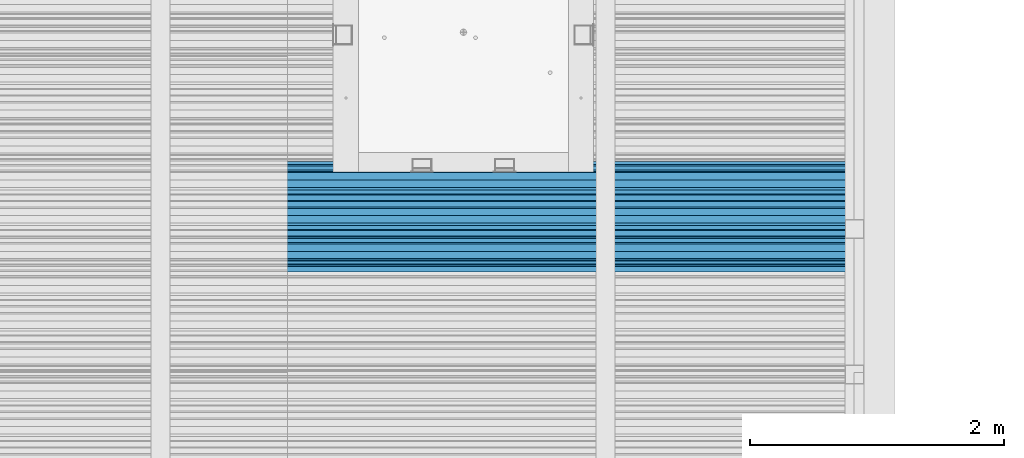
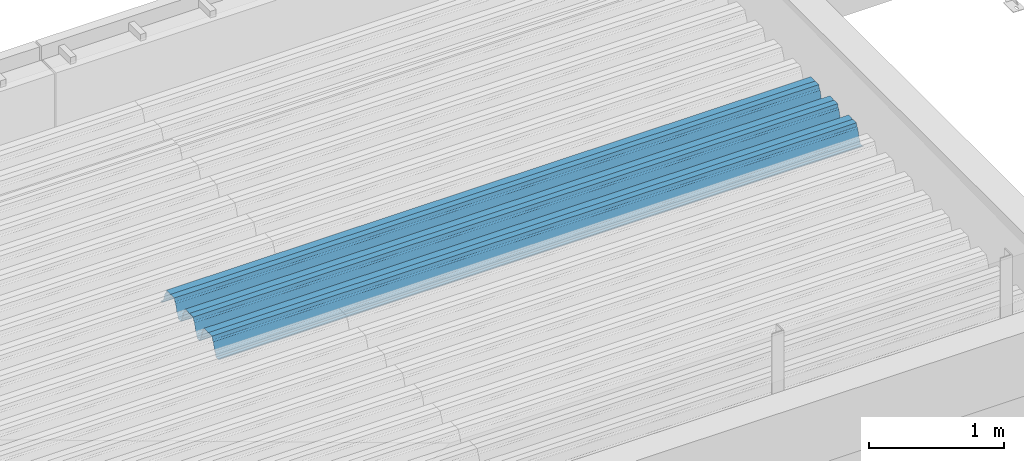
# One storey, part 38 of 153: 1 beam, 1 element without a shape of its own.
"""IFC2X3 building model written with IfcOpenShell, lengths in millimetres."""

from ifc_helpers import new_model, si_unit, frame, origin_with_axes, place, context, subcontext, project, spatial, faceted_brep, material, type_object, element, aggregate, save


model = new_model("IFC2X3")

# Units and contexts
model_context = context("Model", 3, precision=1e-05, world=origin_with_axes())
body_context = subcontext(model_context, "Body", "Model", "MODEL_VIEW")
ifc_project = project(units=[si_unit("LENGTHUNIT", "METRE", prefix="MILLI"), si_unit("AREAUNIT", "SQUARE_METRE"), si_unit("VOLUMEUNIT", "CUBIC_METRE"), si_unit("MASSUNIT", "GRAM", prefix="KILO"), si_unit("TIMEUNIT", "SECOND"), si_unit("PLANEANGLEUNIT", "RADIAN"), si_unit("SOLIDANGLEUNIT", "STERADIAN"), si_unit("THERMODYNAMICTEMPERATUREUNIT", "DEGREE_CELSIUS"), si_unit("LUMINOUSINTENSITYUNIT", "LUMEN")], contexts=[model_context])

# Site, building, storey
site_placement = place(None, origin_with_axes())
site = spatial("IfcSite", under=ifc_project, at=site_placement, CompositionType="ELEMENT")
building_placement = place(site_placement, origin_with_axes())
building = spatial("IfcBuilding", under=site, at=building_placement, CompositionType="ELEMENT")
storey_placement = place(building_placement, origin_with_axes())
storey = spatial("IfcBuildingStorey", under=building, at=storey_placement, Name="8", CompositionType="ELEMENT", Elevation=0.0)

# Assembly, beam
assembly_placement = place(storey_placement, origin_with_axes())
assembly = element("IfcElementAssembly", 1, at=assembly_placement, inside=storey, Name="Steel Assembly", AssemblyPlace="NOTDEFINED", PredefinedType="RIGID_FRAME")
ifc_material = material(Name="STEEL/S355J2")
beam_type = type_object("IfcBeamType", Name="W", PredefinedType="NOTDEFINED")
beam_placement = place(assembly_placement, frame((21782.0, 17875.0145456904, 105781.023065477), z_axis=(0.0, -0.0124990270013869, 0.999921884110963), x_axis=(-1.0, 3.00000001838171e-08, 0.0)))
beam = element("IfcBeam", 2, at=beam_placement, type_object=beam_type, material=ifc_material, ObjectType="W", context=body_context, shape_type="Brep", body=[
    faceted_brep([(0.0, -412.839996337891, -77.0100021362159), (0.0, -409.160003662109, -77.0100021362014), (5530.0, -409.160003662109, -77.0100021362014), (5530.0, -412.839996337891, -77.0100021362159), (0.0, -408.070007324222, -73.4800033569045), (5530.0, -408.070007324222, -73.4800033569045), (0.0, -400.339996337894, -48.0600013732619), (5530.0, -400.339996337894, -48.0600013732619), (0.0, -399.459991455082, -46.5600013732619), (5530.0, -399.459991455082, -46.5600013732619), (0.0, -390.329986572269, -36.5499992370314), (5530.0, -390.329986572269, -36.5499992370314), (0.0, -389.19000244141, -34.6300010680861), (5530.0, -389.19000244141, -34.6300010680861), (0.0, -367.820007324222, 35.3400001526024), (5530.0, -367.820007324222, 35.3400001526024), (0.0, -366.989990234379, 36.8499984741502), (5530.0, -366.989990234379, 36.8499984741502), (0.0, -357.809997558597, 46.8600006103807), (5530.0, -357.809997558597, 46.8600006103807), (0.0, -356.720001220707, 48.7700004577782), (5530.0, -356.720001220707, 48.7700004577782), (0.0, -349.309997558594, 73.1500015258935), (5530.0, -349.309997558594, 73.1500015258935), (0.0, -347.850006103516, 75.2300033569481), (5530.0, -347.850006103516, 75.2300033569481), (0.0, -345.470001220707, 76.010002136245), (5530.0, -345.470001220707, 76.010002136245), (0.0, -305.480010986332, 76.010002136245), (5530.0, -305.480010986332, 76.010002136245), (0.0, -304.279998779301, 75.8000030517578), (5530.0, -304.279998779301, 75.8000030517578), (0.0, -291.679992675785, 71.6999969482567), (5530.0, -291.679992675785, 71.6999969482567), (0.0, -290.179992675789, 71.2300033569481), (5530.0, -290.179992675789, 71.2300033569481), (0.0, -288.720001220707, 71.6999969482567), (5530.0, -288.720001220707, 71.6999969482567), (0.0, -276.119995117191, 75.8000030517869), (5530.0, -276.119995117191, 75.8000030517869), (0.0, -274.929992675785, 76.010002136245), (5530.0, -274.929992675785, 76.010002136245), (0.0, -234.94000244141, 76.010002136245), (5530.0, -234.94000244141, 76.010002136245), (0.0, -232.550003051758, 75.2300033569627), (5530.0, -232.550003051758, 75.2300033569627), (0.0, -231.100006103519, 73.1500015258935), (5530.0, -231.100006103519, 73.1500015258935), (0.0, -223.679992675785, 48.7700004577782), (5530.0, -223.679992675785, 48.7700004577782), (0.0, -222.589996337894, 46.8600006103661), (5530.0, -222.589996337894, 46.8600006103661), (0.0, -213.410003662113, 36.8499984741502), (5530.0, -213.410003662113, 36.8499984741502), (0.0, -212.529998779301, 35.3400001526024), (5530.0, -212.529998779301, 35.3400001526024), (0.0, -191.160003662109, -34.6300010681007), (5530.0, -191.160003662109, -34.6300010681007), (0.0, -190.070007324222, -36.5499992370605), (5530.0, -190.070007324222, -36.5499992370605), (0.0, -180.940002441406, -46.560001373291), (5530.0, -180.940002441406, -46.560001373291), (0.0, -180.059997558597, -48.0600013732619), (5530.0, -180.059997558597, -48.0600013732619), (0.0, -172.330001831055, -73.480003356919), (5530.0, -172.330001831055, -73.480003356919), (0.0, -171.240005493168, -77.0100021362159), (5530.0, -171.240005493168, -77.0100021362159), (0.0, -129.330001831062, -77.0100021362014), (5530.0, -129.330001831062, -77.0100021362014), (0.0, -128.300003051761, -73.480003356919), (5530.0, -128.300003051761, -73.480003356919), (0.0, -120.51999664307, -48.0600013732765), (5530.0, -120.51999664307, -48.0600013732765), (0.0, -119.629997253418, -46.5600013732765), (5530.0, -119.629997253418, -46.5600013732765), (0.0, -110.500000000004, -36.5499992370314), (5530.0, -110.500000000004, -36.5499992370314), (0.0, -109.419998168949, -34.6300010680861), (5530.0, -109.419998168949, -34.6300010680861), (0.0, -88.0500030517615, 35.3400001526024), (5530.0, -88.0500030517615, 35.3400001526024), (0.0, -87.160003662113, 36.8499984741356), (5530.0, -87.160003662113, 36.8499984741356), (0.0, -78.0400009155273, 46.8600006103807), (5530.0, -78.0400009155273, 46.8600006103807), (0.0, -76.8899993896557, 48.7700004577782), (5530.0, -76.8899993896557, 48.7700004577782), (0.0, -69.4800033569336, 73.1500015258935), (5530.0, -69.4800033569336, 73.1500015258935), (0.0, -68.0299987793042, 75.2300033569336), (5530.0, -68.0299987793042, 75.2300033569336), (0.0, -65.6399993896521, 76.010002136245), (5530.0, -65.6399993896521, 76.010002136245), (0.0, -25.6499996185375, 76.0100021362596), (5530.0, -25.6499996185375, 76.0100021362596), (0.0, -24.5100002288891, 75.8000030517724), (5530.0, -24.5100002288891, 75.8000030517724), (0.0, -11.8500003814697, 71.6999969482567), (5530.0, -11.8500003814697, 71.6999969482567), (0.0, -10.3999996185339, 71.2300033569481), (5530.0, -10.3999996185339, 71.2300033569481), (0.0, -8.89999961853391, 71.6999969482567), (5530.0, -8.89999961853391, 71.6999969482567), (0.0, 3.71000003814333, 75.8000030517724), (5530.0, 3.71000003814333, 75.8000030517724), (0.0, 4.90000009536379, 76.0100021362596), (5530.0, 4.90000009536379, 76.0100021362596), (0.0, 44.8899993896484, 76.010002136245), (5530.0, 44.8899993896484, 76.010002136245), (0.0, 47.2799987792932, 75.2300033569481), (5530.0, 47.2799987792932, 75.2300033569481), (0.0, 48.6800003051721, 73.1500015258935), (5530.0, 48.6800003051721, 73.1500015258935), (0.0, 56.1500015258753, 48.7700004577782), (5530.0, 56.1500015258753, 48.7700004577782), (0.0, 57.2400016784632, 46.8600006103807), (5530.0, 57.2400016784632, 46.8600006103807), (0.0, 66.3700027465784, 36.8499984741211), (5530.0, 66.3700027465784, 36.8499984741211), (0.0, 67.2499999999964, 35.3400001526024), (5530.0, 67.2499999999964, 35.3400001526024), (0.0, 88.6200027465748, -34.6300010681007), (5530.0, 88.6200027465748, -34.6300010681007), (0.0, 89.709999084469, -36.549999237046), (5530.0, 89.709999084469, -36.549999237046), (0.0, 98.8899993896412, -46.5600013732765), (5530.0, 98.8899993896412, -46.5600013732765), (0.0, 99.7699966430628, -48.0600013732765), (5530.0, 99.7699966430628, -48.0600013732765), (0.0, 107.499999999996, -73.4800033569336), (5530.0, 107.499999999996, -73.4800033569336), (0.0, 108.589996337887, -77.0100021362014), (5530.0, 108.589996337887, -77.0100021362014), (0.0, 112.269996643063, -77.0100021362159), (5530.0, 112.269996643063, -77.0100021362159), (0.0, 146.759994506836, -77.0100021362159), (5530.0, 146.759994506836, -77.0100021362159), (0.0, 150.440002441403, -77.0100021362159), (5530.0, 150.440002441403, -77.0100021362159), (0.0, 151.529998779297, -73.480003356919), (5530.0, 151.529998779297, -73.480003356919), (0.0, 159.30999755859, -48.0600013732765), (5530.0, 159.30999755859, -48.0600013732765), (0.0, 160.190002441406, -46.5600013732619), (5530.0, 160.190002441406, -46.5600013732619), (0.0, 169.320007324215, -36.549999237046), (5530.0, 169.320007324215, -36.549999237046), (0.0, 170.410003662106, -34.6300010680861), (5530.0, 170.410003662106, -34.6300010680861), (0.0, 191.779998779293, 35.3400001526024), (5530.0, 191.779998779293, 35.3400001526024), (0.0, 192.660003662109, 36.8499984741502), (5530.0, 192.660003662109, 36.8499984741502), (0.0, 201.789993286129, 46.8600006103661), (5530.0, 201.789993286129, 46.8600006103661), (0.0, 202.880004882809, 48.7700004577637), (5530.0, 202.880004882809, 48.7700004577637), (0.0, 210.350006103512, 73.150001525908), (5530.0, 210.350006103512, 73.150001525908), (0.0, 211.800003051754, 75.2300033569481), (5530.0, 211.800003051754, 75.2300033569481), (0.0, 214.190002441406, 76.010002136245), (5530.0, 214.190002441406, 76.010002136245), (0.0, 254.179992675778, 76.010002136245), (5530.0, 254.179992675778, 76.010002136245), (0.0, 255.320007324215, 75.8000030517869), (5530.0, 255.320007324215, 75.8000030517869), (0.0, 267.980010986324, 71.6999969482713), (5530.0, 267.980010986324, 71.6999969482713), (0.0, 269.429992675778, 71.2300033569481), (5530.0, 269.429992675778, 71.2300033569481), (0.0, 270.880004882809, 71.6999969482567), (5530.0, 270.880004882809, 71.6999969482567), (0.0, 283.540008544918, 75.8000030517869), (5530.0, 283.540008544918, 75.8000030517869), (0.0, 284.679992675778, 76.010002136245), (5530.0, 284.679992675778, 76.010002136245), (0.0, 324.670013427731, 76.010002136245), (5530.0, 324.670013427731, 76.010002136245), (0.0, 327.049987792969, 75.2300033569627), (5530.0, 327.049987792969, 75.2300033569627), (0.0, 328.510009765625, 73.1500015258789), (5530.0, 328.510009765625, 73.1500015258789), (0.0, 335.980010986324, 48.7700004577782), (5530.0, 335.980010986324, 48.7700004577782), (0.0, 337.05999755859, 46.8600006103661), (5530.0, 337.05999755859, 46.8600006103661), (0.0, 346.190002441399, 36.8499984741356), (5530.0, 346.190002441399, 36.8499984741356), (0.0, 347.079986572266, 35.3400001526024), (5530.0, 347.079986572266, 35.3400001526024), (0.0, 368.450012207028, -34.6300010680861), (5530.0, 368.450012207028, -34.6300010680861), (0.0, 369.529998779293, -36.5499992370314), (5530.0, 369.529998779293, -36.5499992370314), (0.0, 378.660003662106, -46.5600013732619), (5530.0, 378.660003662106, -46.5600013732619), (0.0, 379.540008544918, -48.0600013732619), (5530.0, 379.540008544918, -48.0600013732619), (0.0, 387.329986572262, -73.480003356919), (5530.0, 387.329986572262, -73.480003356919), (0.0, 388.410003662109, -77.0100021362159), (5530.0, 388.410003662109, -77.0100021362159), (0.0, 392.100006103512, -77.0100021362159), (5530.0, 392.100006103512, -77.0100021362159), (0.0, 426.589996337887, -77.0100021362159), (5530.0, 426.589996337887, -77.0100021362159), (0.0, 430.269989013668, -77.0100021362159), (5530.0, 430.269989013668, -77.0100021362159), (0.0, 431.359985351559, -73.4800033569045), (5530.0, 431.359985351559, -73.4800033569045), (0.0, 433.179992675778, -67.5699996948097), (5530.0, 433.179992675778, -67.5699996948097), (0.0, 432.220001220699, -67.2699966430373), (5530.0, 432.220001220699, -67.2699966430373), (0.0, 430.410003662106, -73.1800003051612), (5530.0, 430.410003662106, -73.1800003051612), (0.0, 429.529998779293, -76.0100021362159), (5530.0, 429.529998779293, -76.0100021362159), (0.0, 426.589996337891, -76.0100021362159), (5530.0, 426.589996337891, -76.0100021362159), (0.0, 392.100006103512, -76.0100021362159), (5530.0, 392.100006103512, -76.0100021362159), (0.0, 389.149993896481, -76.0100021362014), (5530.0, 389.149993896481, -76.0100021362014), (0.0, 388.279998779293, -73.1800003051467), (5530.0, 388.279998779293, -73.1800003051467), (0.0, 380.470001220699, -47.659999847383), (5530.0, 380.470001220699, -47.659999847383), (0.0, 379.470001220699, -45.9599990844436), (5530.0, 379.470001220699, -45.9599990844436), (0.0, 370.350006103512, -35.9599990844581), (5530.0, 370.350006103512, -35.9599990844581), (0.0, 369.369995117184, -34.2299995422218), (5530.0, 369.369995117184, -34.2299995422218), (0.0, 347.999999999996, 35.7500000000146), (5530.0, 347.999999999996, 35.7500000000146), (0.0, 346.999999999996, 37.4399986267235), (5530.0, 346.999999999996, 37.4399986267235), (0.0, 337.880004882809, 47.450000762954), (5530.0, 337.880004882809, 47.450000762954), (0.0, 336.899993896481, 49.1699981689453), (5530.0, 336.899993896481, 49.1699981689453), (0.0, 329.420013427731, 73.5999984741356), (5530.0, 329.420013427731, 73.5999984741356), (0.0, 327.679992675781, 76.0699996948533), (5530.0, 327.679992675781, 76.0699996948533), (0.0, 324.829986572262, 77.010002136245), (5530.0, 324.829986572262, 77.010002136245), (0.0, 284.589996337887, 77.010002136245), (5530.0, 284.589996337887, 77.010002136245), (0.0, 283.290008544922, 76.769996643081), (5530.0, 283.290008544922, 76.769996643081), (0.0, 270.570007324215, 72.6500015258935), (5530.0, 270.570007324215, 72.6500015258935), (0.0, 269.429992675781, 72.2799987793114), (5530.0, 269.429992675781, 72.2799987793114), (0.0, 268.279998779293, 72.650001525908), (5530.0, 268.279998779293, 72.650001525908), (0.0, 255.570007324219, 76.769996643081), (5530.0, 255.570007324219, 76.769996643081), (0.0, 254.270004272461, 77.0100021362596), (5530.0, 254.270004272461, 77.0100021362596), (0.0, 214.029998779293, 77.0100021362596), (5530.0, 214.029998779293, 77.0100021362596), (0.0, 211.179992675781, 76.0699996948388), (5530.0, 211.179992675781, 76.0699996948388), (0.0, 209.440002441403, 73.5999984741356), (5530.0, 209.440002441403, 73.5999984741356), (0.0, 201.960006713864, 49.1699981689599), (5530.0, 201.960006713864, 49.1699981689599), (0.0, 200.979995727532, 47.450000762954), (5530.0, 200.979995727532, 47.450000762954), (0.0, 191.850006103508, 37.4399986267235), (5530.0, 191.850006103508, 37.4399986267235), (0.0, 190.860000610352, 35.7500000000146), (5530.0, 190.860000610352, 35.7500000000146), (0.0, 169.49000549316, -34.2299995422218), (5530.0, 169.49000549316, -34.2299995422218), (0.0, 168.509994506832, -35.9599990844581), (5530.0, 168.509994506832, -35.9599990844581), (0.0, 159.380004882805, -45.9599990844436), (5530.0, 159.380004882805, -45.9599990844436), (0.0, 158.389999389645, -47.6599998473976), (5530.0, 158.389999389645, -47.6599998473976), (0.0, 150.580001831051, -73.1800003051612), (5530.0, 150.580001831051, -73.1800003051612), (0.0, 149.710006713864, -76.0100021362159), (5530.0, 149.710006713864, -76.0100021362159), (0.0, 146.759994506836, -76.0100021362159), (5530.0, 146.759994506836, -76.0100021362159), (0.0, 112.269996643063, -76.0100021362159), (5530.0, 112.269996643063, -76.0100021362159), (0.0, 109.319999694821, -76.0100021362159), (5530.0, 109.319999694821, -76.0100021362159), (0.0, 108.449996948239, -73.1900024413917), (5530.0, 108.449996948239, -73.1900024413917), (0.0, 100.690002441406, -47.659999847383), (5530.0, 100.690002441406, -47.659999847383), (0.0, 99.6999969482386, -45.9599990844581), (5530.0, 99.6999969482386, -45.9599990844581), (0.0, 90.5199966430664, -35.9599990844581), (5530.0, 90.5199966430664, -35.9599990844581), (0.0, 89.5400009155273, -34.2299995422218), (5530.0, 89.5400009155273, -34.2299995422218), (0.0, 68.1699981689417, 35.7500000000146), (5530.0, 68.1699981689417, 35.7500000000146), (0.0, 67.1699981689417, 37.4399986267235), (5530.0, 67.1699981689417, 37.4399986267235), (0.0, 58.0499992370569, 47.4500007629686), (5530.0, 58.0499992370569, 47.4500007629686), (0.0, 57.0699996948206, 49.1699981689599), (5530.0, 57.0699996948206, 49.1699981689599), (0.0, 49.5900001525843, 73.5899963379052), (5530.0, 49.5900001525843, 73.5899963379052), (0.0, 47.9099998474085, 76.0699996948388), (5530.0, 47.9099998474085, 76.0699996948388), (0.0, 45.0499992370569, 77.010002136245), (5530.0, 45.0499992370569, 77.010002136245), (0.0, 4.82000017165774, 77.010002136245), (5530.0, 4.82000017165774, 77.010002136245), (0.0, 3.47000002860659, 76.7699966430955), (5530.0, 3.47000002860659, 76.7699966430955), (0.0, -9.19999980926514, 72.6500015258935), (5530.0, -9.19999980926514, 72.6500015258935), (0.0, -10.3900003433264, 72.2799987792969), (5530.0, -10.3900003433264, 72.2799987792969), (0.0, -11.5399999618567, 72.6500015258935), (5530.0, -11.5399999618567, 72.6500015258935), (0.0, -24.2600002288855, 76.769996643081), (5530.0, -24.2600002288855, 76.769996643081), (0.0, -25.559999465946, 77.0100021362596), (5530.0, -25.559999465946, 77.0100021362596), (0.0, -65.8000030517615, 77.0100021362596), (5530.0, -65.8000030517615, 77.0100021362596), (0.0, -68.6500015258862, 76.0699996948533), (5530.0, -68.6500015258862, 76.0699996948533), (0.0, -70.3899993896521, 73.5999984741356), (5530.0, -70.3899993896521, 73.5999984741356), (0.0, -77.8199996948242, 49.1800003051903), (5530.0, -77.8199996948242, 49.1800003051903), (0.0, -78.8399963378943, 47.450000762954), (5530.0, -78.8399963378943, 47.450000762954), (0.0, -87.9700012207031, 37.4399986267235), (5530.0, -87.9700012207031, 37.4399986267235), (0.0, -88.9700012207068, 35.7500000000146), (5530.0, -88.9700012207068, 35.7500000000146), (0.0, -110.339996337894, -34.2299995422218), (5530.0, -110.339996337894, -34.2299995422218), (0.0, -111.319999694828, -35.9599990844581), (5530.0, -111.319999694828, -35.9599990844581), (0.0, -120.440002441406, -45.9599990844436), (5530.0, -120.440002441406, -45.9599990844436), (0.0, -121.44000244141, -47.6599998473976), (5530.0, -121.44000244141, -47.6599998473976), (0.0, -129.250000000004, -73.1900024413771), (5530.0, -129.250000000004, -73.1900024413771), (0.0, -130.080001831062, -76.0100021362159), (5530.0, -130.080001831062, -76.0100021362159), (0.0, -170.5, -76.0100021362014), (5530.0, -170.5, -76.0100021362014), (0.0, -171.380004882816, -73.1900024413917), (5530.0, -171.380004882816, -73.1900024413917), (0.0, -179.139999389652, -47.6599998473976), (5530.0, -179.139999389652, -47.6599998473976), (0.0, -180.130004882816, -45.9599990844581), (5530.0, -180.130004882816, -45.9599990844581), (0.0, -189.259994506836, -35.9599990844581), (5530.0, -189.259994506836, -35.9599990844581), (0.0, -190.240005493168, -34.2299995422218), (5530.0, -190.240005493168, -34.2299995422218), (0.0, -211.610000610355, 35.7500000000146), (5530.0, -211.610000610355, 35.7500000000146), (0.0, -212.600006103519, 37.4399986267381), (5530.0, -212.600006103519, 37.4399986267381), (0.0, -221.779998779301, 47.450000762954), (5530.0, -221.779998779301, 47.450000762954), (0.0, -222.75999450684, 49.1699981689599), (5530.0, -222.75999450684, 49.1699981689599), (0.0, -230.190002441406, 73.5999984741356), (5530.0, -230.190002441406, 73.5999984741356), (0.0, -231.919998168945, 76.0699996948388), (5530.0, -231.919998168945, 76.0699996948388), (0.0, -234.779998779301, 77.010002136245), (5530.0, -234.779998779301, 77.010002136245), (0.0, -275.010009765629, 77.010002136245), (5530.0, -275.010009765629, 77.010002136245), (0.0, -276.359985351563, 76.769996643081), (5530.0, -276.359985351563, 76.769996643081), (0.0, -289.029998779297, 72.6500015258789), (5530.0, -289.029998779297, 72.6500015258789), (0.0, -290.179992675785, 72.2799987793114), (5530.0, -290.179992675785, 72.2799987793114), (0.0, -291.380004882816, 72.650001525908), (5530.0, -291.380004882816, 72.650001525908), (0.0, -304.040008544926, 76.769996643081), (5530.0, -304.040008544926, 76.769996643081), (0.0, -305.390014648441, 77.010002136245), (5530.0, -305.390014648441, 77.010002136245), (0.0, -345.63000488282, 77.0100021362596), (5530.0, -345.63000488282, 77.0100021362596), (0.0, -348.480010986332, 76.0699996948388), (5530.0, -348.480010986332, 76.0699996948388), (0.0, -350.220001220707, 73.5999984741356), (5530.0, -350.220001220707, 73.5999984741356), (0.0, -357.649993896492, 49.1699981689599), (5530.0, -357.649993896492, 49.1699981689599), (0.0, -358.63000488282, 47.450000762954), (5530.0, -358.63000488282, 47.450000762954), (0.0, -367.809997558594, 37.4300003051903), (5530.0, -367.809997558594, 37.4300003051903), (0.0, -368.750000000004, 35.7299995422654), (5530.0, -368.750000000004, 35.7299995422654), (0.0, -390.109985351566, -34.2200012207031), (5530.0, -390.109985351566, -34.2200012207031), (0.0, -391.140014648441, -35.9500007629249), (5530.0, -391.140014648441, -35.9500007629249), (0.0, -400.269989013676, -45.9599990844436), (5530.0, -400.269989013676, -45.9599990844436), (0.0, -401.269989013672, -47.6599998473976), (5530.0, -401.269989013672, -47.6599998473976), (0.0, -409.029998779297, -73.1900024413917), (5530.0, -409.029998779297, -73.1900024413917), (0.0, -409.899993896488, -76.0100021362159), (5530.0, -409.899993896488, -76.0100021362159), (0.0, -412.839996337891, -76.0100021362159), (5530.0, -412.839996337891, -76.0100021362159), (0.0, -433.179992675785, -76.0100021362159), (5530.0, -433.179992675785, -76.0100021362159), (0.0, -433.179992675785, -77.0100021362159), (5530.0, -433.179992675785, -77.0100021362159)], [[[0, 1, 2, 3]], [[1, 4, 5, 2]], [[4, 6, 7, 5]], [[6, 8, 9, 7]], [[8, 10, 11, 9]], [[10, 12, 13, 11]], [[12, 14, 15, 13]], [[14, 16, 17, 15]], [[16, 18, 19, 17]], [[18, 20, 21, 19]], [[20, 22, 23, 21]], [[22, 24, 25, 23]], [[24, 26, 27, 25]], [[26, 28, 29, 27]], [[28, 30, 31, 29]], [[30, 32, 33, 31]], [[32, 34, 35, 33]], [[34, 36, 37, 35]], [[36, 38, 39, 37]], [[38, 40, 41, 39]], [[40, 42, 43, 41]], [[42, 44, 45, 43]], [[44, 46, 47, 45]], [[46, 48, 49, 47]], [[48, 50, 51, 49]], [[50, 52, 53, 51]], [[52, 54, 55, 53]], [[54, 56, 57, 55]], [[56, 58, 59, 57]], [[58, 60, 61, 59]], [[60, 62, 63, 61]], [[62, 64, 65, 63]], [[64, 66, 67, 65]], [[66, 68, 69, 67]], [[68, 70, 71, 69]], [[70, 72, 73, 71]], [[72, 74, 75, 73]], [[74, 76, 77, 75]], [[76, 78, 79, 77]], [[78, 80, 81, 79]], [[80, 82, 83, 81]], [[82, 84, 85, 83]], [[84, 86, 87, 85]], [[86, 88, 89, 87]], [[88, 90, 91, 89]], [[90, 92, 93, 91]], [[92, 94, 95, 93]], [[94, 96, 97, 95]], [[96, 98, 99, 97]], [[98, 100, 101, 99]], [[100, 102, 103, 101]], [[102, 104, 105, 103]], [[104, 106, 107, 105]], [[106, 108, 109, 107]], [[108, 110, 111, 109]], [[110, 112, 113, 111]], [[112, 114, 115, 113]], [[114, 116, 117, 115]], [[116, 118, 119, 117]], [[118, 120, 121, 119]], [[120, 122, 123, 121]], [[122, 124, 125, 123]], [[124, 126, 127, 125]], [[126, 128, 129, 127]], [[128, 130, 131, 129]], [[130, 132, 133, 131]], [[132, 134, 135, 133]], [[134, 136, 137, 135]], [[136, 138, 139, 137]], [[138, 140, 141, 139]], [[140, 142, 143, 141]], [[142, 144, 145, 143]], [[144, 146, 147, 145]], [[146, 148, 149, 147]], [[148, 150, 151, 149]], [[150, 152, 153, 151]], [[152, 154, 155, 153]], [[154, 156, 157, 155]], [[156, 158, 159, 157]], [[158, 160, 161, 159]], [[160, 162, 163, 161]], [[162, 164, 165, 163]], [[164, 166, 167, 165]], [[166, 168, 169, 167]], [[168, 170, 171, 169]], [[170, 172, 173, 171]], [[172, 174, 175, 173]], [[174, 176, 177, 175]], [[176, 178, 179, 177]], [[178, 180, 181, 179]], [[180, 182, 183, 181]], [[182, 184, 185, 183]], [[184, 186, 187, 185]], [[186, 188, 189, 187]], [[188, 190, 191, 189]], [[190, 192, 193, 191]], [[192, 194, 195, 193]], [[194, 196, 197, 195]], [[196, 198, 199, 197]], [[198, 200, 201, 199]], [[200, 202, 203, 201]], [[202, 204, 205, 203]], [[204, 206, 207, 205]], [[206, 208, 209, 207]], [[208, 210, 211, 209]], [[210, 212, 213, 211]], [[212, 214, 215, 213]], [[214, 216, 217, 215]], [[216, 218, 219, 217]], [[218, 220, 221, 219]], [[220, 222, 223, 221]], [[222, 224, 225, 223]], [[224, 226, 227, 225]], [[226, 228, 229, 227]], [[228, 230, 231, 229]], [[230, 232, 233, 231]], [[232, 234, 235, 233]], [[234, 236, 237, 235]], [[236, 238, 239, 237]], [[238, 240, 241, 239]], [[240, 242, 243, 241]], [[242, 244, 245, 243]], [[244, 246, 247, 245]], [[246, 248, 249, 247]], [[248, 250, 251, 249]], [[250, 252, 253, 251]], [[252, 254, 255, 253]], [[254, 256, 257, 255]], [[256, 258, 259, 257]], [[258, 260, 261, 259]], [[260, 262, 263, 261]], [[262, 264, 265, 263]], [[264, 266, 267, 265]], [[266, 268, 269, 267]], [[268, 270, 271, 269]], [[270, 272, 273, 271]], [[272, 274, 275, 273]], [[274, 276, 277, 275]], [[276, 278, 279, 277]], [[278, 280, 281, 279]], [[280, 282, 283, 281]], [[282, 284, 285, 283]], [[284, 286, 287, 285]], [[286, 288, 289, 287]], [[288, 290, 291, 289]], [[290, 292, 293, 291]], [[292, 294, 295, 293]], [[294, 296, 297, 295]], [[296, 298, 299, 297]], [[298, 300, 301, 299]], [[300, 302, 303, 301]], [[302, 304, 305, 303]], [[304, 306, 307, 305]], [[306, 308, 309, 307]], [[308, 310, 311, 309]], [[310, 312, 313, 311]], [[312, 314, 315, 313]], [[314, 316, 317, 315]], [[316, 318, 319, 317]], [[318, 320, 321, 319]], [[320, 322, 323, 321]], [[322, 324, 325, 323]], [[324, 326, 327, 325]], [[326, 328, 329, 327]], [[328, 330, 331, 329]], [[330, 332, 333, 331]], [[332, 334, 335, 333]], [[334, 336, 337, 335]], [[336, 338, 339, 337]], [[338, 340, 341, 339]], [[340, 342, 343, 341]], [[342, 344, 345, 343]], [[344, 346, 347, 345]], [[346, 348, 349, 347]], [[348, 350, 351, 349]], [[350, 352, 353, 351]], [[352, 354, 355, 353]], [[354, 356, 357, 355]], [[356, 358, 359, 357]], [[358, 360, 361, 359]], [[360, 362, 363, 361]], [[362, 364, 365, 363]], [[364, 366, 367, 365]], [[366, 368, 369, 367]], [[368, 370, 371, 369]], [[370, 372, 373, 371]], [[372, 374, 375, 373]], [[374, 376, 377, 375]], [[376, 378, 379, 377]], [[378, 380, 381, 379]], [[380, 382, 383, 381]], [[382, 384, 385, 383]], [[384, 386, 387, 385]], [[386, 388, 389, 387]], [[388, 390, 391, 389]], [[390, 392, 393, 391]], [[392, 394, 395, 393]], [[394, 396, 397, 395]], [[396, 398, 399, 397]], [[398, 400, 401, 399]], [[400, 402, 403, 401]], [[402, 404, 405, 403]], [[404, 406, 407, 405]], [[406, 408, 409, 407]], [[408, 410, 411, 409]], [[410, 412, 413, 411]], [[412, 414, 415, 413]], [[414, 416, 417, 415]], [[416, 418, 419, 417]], [[418, 420, 421, 419]], [[420, 422, 423, 421]], [[422, 424, 425, 423]], [[424, 426, 427, 425]], [[426, 428, 429, 427]], [[428, 430, 431, 429]], [[430, 0, 3, 431]], [[5, 7, 9, 11, 13, 15, 17, 19, 21, 23, 25, 27, 29, 31, 33, 35, 37, 39, 41, 43, 45, 47, 49, 51, 53, 55, 57, 59, 61, 63, 65, 67, 69, 71, 73, 75, 77, 79, 81, 83, 85, 87, 89, 91, 93, 95, 97, 99, 101, 103, 105, 107, 109, 111, 113, 115, 117, 119, 121, 123, 125, 127, 129, 131, 133, 135, 137, 139, 141, 143, 145, 147, 149, 151, 153, 155, 157, 159, 161, 163, 165, 167, 169, 171, 173, 175, 177, 179, 181, 183, 185, 187, 189, 191, 193, 195, 197, 199, 201, 203, 205, 207, 209, 211, 213, 215, 217, 219, 221, 223, 225, 227, 229, 231, 233, 235, 237, 239, 241, 243, 245, 247, 249, 251, 253, 255, 257, 259, 261, 263, 265, 267, 269, 271, 273, 275, 277, 279, 281, 283, 285, 287, 289, 291, 293, 295, 297, 299, 301, 303, 305, 307, 309, 311, 313, 315, 317, 319, 321, 323, 325, 327, 329, 331, 333, 335, 337, 339, 341, 343, 345, 347, 349, 351, 353, 355, 357, 359, 361, 363, 365, 367, 369, 371, 373, 375, 377, 379, 381, 383, 385, 387, 389, 391, 393, 395, 397, 399, 401, 403, 405, 407, 409, 411, 413, 415, 417, 419, 421, 423, 425, 427, 429, 431, 3, 2]], [[430, 428, 426, 424, 422, 420, 418, 416, 414, 412, 410, 408, 406, 404, 402, 400, 398, 396, 394, 392, 390, 388, 386, 384, 382, 380, 378, 376, 374, 372, 370, 368, 366, 364, 362, 360, 358, 356, 354, 352, 350, 348, 346, 344, 342, 340, 338, 336, 334, 332, 330, 328, 326, 324, 322, 320, 318, 316, 314, 312, 310, 308, 306, 304, 302, 300, 298, 296, 294, 292, 290, 288, 286, 284, 282, 280, 278, 276, 274, 272, 270, 268, 266, 264, 262, 260, 258, 256, 254, 252, 250, 248, 246, 244, 242, 240, 238, 236, 234, 232, 230, 228, 226, 224, 222, 220, 218, 216, 214, 212, 210, 208, 206, 204, 202, 200, 198, 196, 194, 192, 190, 188, 186, 184, 182, 180, 178, 176, 174, 172, 170, 168, 166, 164, 162, 160, 158, 156, 154, 152, 150, 148, 146, 144, 142, 140, 138, 136, 134, 132, 130, 128, 126, 124, 122, 120, 118, 116, 114, 112, 110, 108, 106, 104, 102, 100, 98, 96, 94, 92, 90, 88, 86, 84, 82, 80, 78, 76, 74, 72, 70, 68, 66, 64, 62, 60, 58, 56, 54, 52, 50, 48, 46, 44, 42, 40, 38, 36, 34, 32, 30, 28, 26, 24, 22, 20, 18, 16, 14, 12, 10, 8, 6, 4, 1, 0]]]),
])
aggregate(assembly, [beam])

save(model, "model.ifc")
